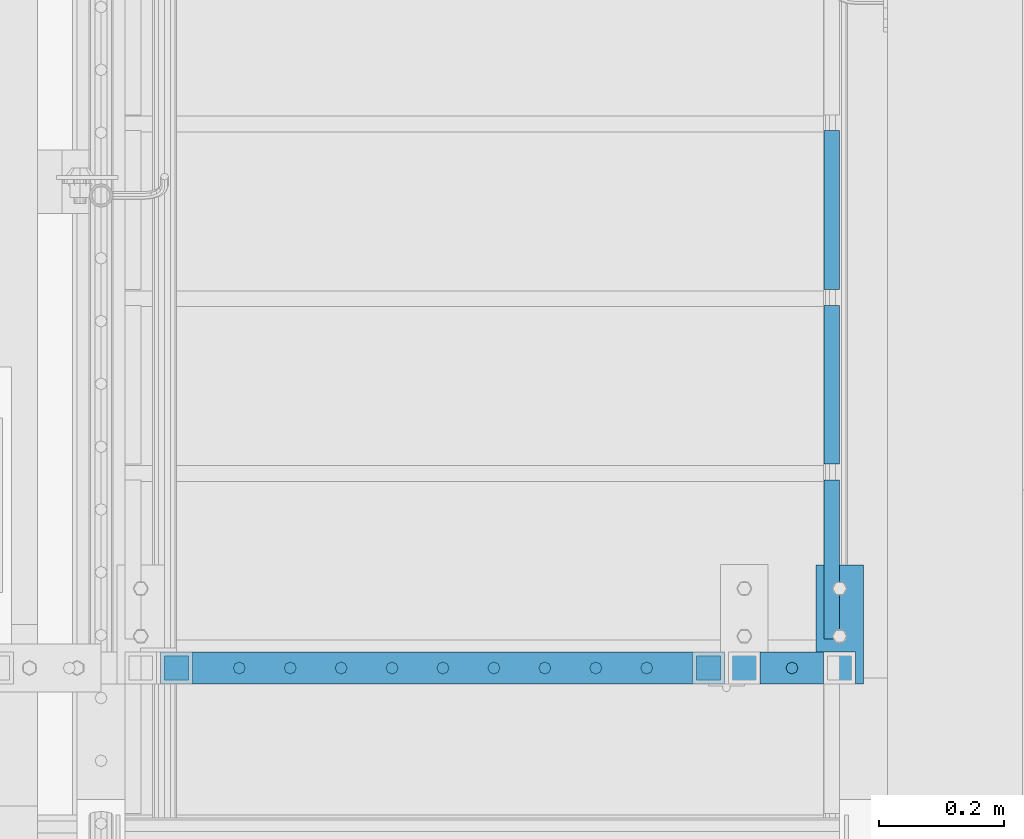
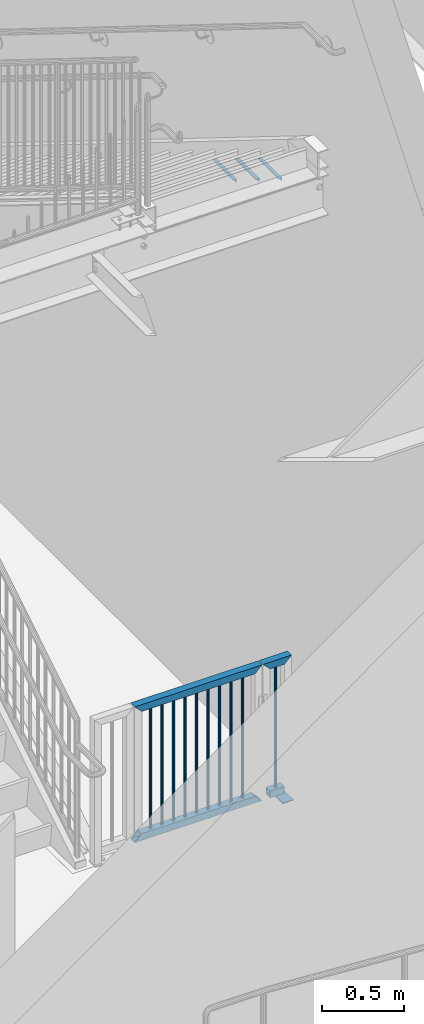
# One storey, part 1264 of 1763: 18 beams, 2 elements without a shape of their own.
"""IFC2X3 building model written with IfcOpenShell, lengths in millimetres."""

from ifc_helpers import new_model, si_unit, frame, origin_with_axes, place, context, subcontext, project, spatial, faceted_brep, material, type_object, element, aggregate, save


model = new_model("IFC2X3")

# Units and contexts
model_context = context("Model", 3, precision=1e-05, world=origin_with_axes())
body_context = subcontext(model_context, "Body", "Model", "MODEL_VIEW")
ifc_project = project(units=[si_unit("LENGTHUNIT", "METRE", prefix="MILLI"), si_unit("AREAUNIT", "SQUARE_METRE"), si_unit("VOLUMEUNIT", "CUBIC_METRE"), si_unit("MASSUNIT", "GRAM", prefix="KILO"), si_unit("TIMEUNIT", "SECOND"), si_unit("PLANEANGLEUNIT", "RADIAN"), si_unit("SOLIDANGLEUNIT", "STERADIAN"), si_unit("THERMODYNAMICTEMPERATUREUNIT", "DEGREE_CELSIUS"), si_unit("LUMINOUSINTENSITYUNIT", "LUMEN")], contexts=[model_context])

# Site, building, storey
site_placement = place(None, origin_with_axes())
site = spatial("IfcSite", under=ifc_project, at=site_placement, CompositionType="ELEMENT")
building_placement = place(site_placement, origin_with_axes())
building = spatial("IfcBuilding", under=site, at=building_placement, Name="Undefined", CompositionType="ELEMENT")
storey_placement = place(building_placement, origin_with_axes())
storey = spatial("IfcBuildingStorey", under=building, at=storey_placement, Name="Undefined", CompositionType="ELEMENT", Elevation=0.0)

# Assembly, beams
assembly_1_placement = place(storey_placement, origin_with_axes())
assembly_1 = element("IfcElementAssembly", 1, at=assembly_1_placement, inside=storey, Name="GATE", AssemblyPlace="NOTDEFINED", PredefinedType="RIGID_FRAME")
ifc_material_1 = material(Name="STEEL/A36")
beam_type_1 = type_object("IfcBeamType", PredefinedType="NOTDEFINED")
beam_1_placement = place(assembly_1_placement, frame((-84136.9372737343, 32092.9000064728, 307.975030132566), z_axis=(0.0, 1.0, 0.0), x_axis=(1.0, 0.0, 0.0)))
beam_1 = element("IfcBeam", 2, at=beam_1_placement, type_object=beam_type_1, material=ifc_material_1, context=body_context, shape_type="Brep", body=[
    faceted_brep([(0.0, 3.17500000000001, -95.25), (0.0, 3.17499999999927, 95.25), (76.1999968561649, 3.17499999984284, 95.25), (76.1999999999971, 3.17500000000001, -95.25), (0.0, -3.17499999999927, 95.25), (76.1999970403122, -3.17500000015571, 95.25), (0.0, -3.17500000000001, -95.25), (76.1999999999971, -3.17500000000001, -95.25)], [[[0, 1, 2, 3]], [[1, 4, 5, 2]], [[4, 6, 7, 5]], [[6, 0, 3, 7]], [[5, 7, 3, 2]], [[6, 4, 1, 0]]]),
])
beam_type_2 = type_object("IfcBeamType", PredefinedType="NOTDEFINED")
beam_2_placement = place(assembly_1_placement, frame((-84407.3725678519, 32023.0500064728, 1346.20003013257), z_axis=(1.0, 0.0, 0.0), x_axis=(0.0, 0.0, -1.0)))
beam_2 = element("IfcBeam", 3, at=beam_2_placement, type_object=beam_type_2, material=ifc_material_1, Name="PICKET", context=body_context, shape_type="Brep", body=[
    faceted_brep([(0.0, -9.52500000000146, 0.0), (0.0, -6.73519209080041, -6.73519209079677), (913.809358181841, -6.73519209080041, -6.73519209079677), (913.809358181841, -9.52500000000146, 0.0), (0.0, 0.0, -9.52499999999418), (913.809358181841, 0.0, -9.52499999999418), (0.0, 6.73519209080041, -6.73519209079677), (913.809358181841, 6.73519209080041, -6.73519209079677), (0.0, 9.52500000000146, 0.0), (913.809358181841, 9.52500000000146, 0.0), (0.0, 6.73519209080041, 6.73519209079677), (913.809358181841, 6.73519209080041, 6.73519209079677), (0.0, 0.0, 9.52499999999418), (913.809358181841, 0.0, 9.52499999999418), (0.0, -6.73519209080041, 6.73519209079677), (913.809358181841, -6.73519209080041, 6.73519209079677)], [[[0, 1, 2, 3]], [[1, 4, 5, 2]], [[4, 6, 7, 5]], [[6, 8, 9, 7]], [[8, 10, 11, 9]], [[10, 12, 13, 11]], [[12, 14, 15, 13]], [[14, 0, 3, 15]], [[5, 7, 9, 11, 13, 15, 3, 2]], [[14, 12, 10, 8, 6, 4, 1, 0]]]),
])
beam_3_placement = place(assembly_1_placement, frame((-84488.8019796166, 32023.0500064728, 1346.20003013257), z_axis=(1.0, 0.0, 0.0), x_axis=(0.0, 0.0, -1.0)))
beam_3 = element("IfcBeam", 4, at=beam_3_placement, type_object=beam_type_2, material=ifc_material_1, Name="PICKET", context=body_context, shape_type="Brep", body=[
    faceted_brep([(0.0, -9.52500000000146, 0.0), (0.0, -6.73519209080041, -6.73519209079677), (913.809358181841, -6.73519209080041, -6.73519209079677), (913.809358181841, -9.52500000000146, 0.0), (0.0, 0.0, -9.52499999999418), (913.809358181841, 0.0, -9.52499999999418), (0.0, 6.73519209080041, -6.73519209079677), (913.809358181841, 6.73519209080041, -6.73519209079677), (0.0, 9.52500000000146, 0.0), (913.809358181841, 9.52500000000146, 0.0), (0.0, 6.73519209080041, 6.73519209079677), (913.809358181841, 6.73519209080041, 6.73519209079677), (0.0, 0.0, 9.52499999999418), (913.809358181841, 0.0, 9.52499999999418), (0.0, -6.73519209080041, 6.73519209079677), (913.809358181841, -6.73519209080041, 6.73519209079677)], [[[0, 1, 2, 3]], [[1, 4, 5, 2]], [[4, 6, 7, 5]], [[6, 8, 9, 7]], [[8, 10, 11, 9]], [[10, 12, 13, 11]], [[12, 14, 15, 13]], [[14, 0, 3, 15]], [[5, 7, 9, 11, 13, 15, 3, 2]], [[14, 12, 10, 8, 6, 4, 1, 0]]]),
])
beam_4_placement = place(assembly_1_placement, frame((-84570.2313913813, 32023.0500064728, 1346.20003013257), z_axis=(1.0, 0.0, 0.0), x_axis=(0.0, 0.0, -1.0)))
beam_4 = element("IfcBeam", 5, at=beam_4_placement, type_object=beam_type_2, material=ifc_material_1, Name="PICKET", context=body_context, shape_type="Brep", body=[
    faceted_brep([(0.0, -9.52500000000146, 0.0), (0.0, -6.73519209080041, -6.73519209079677), (913.809358181841, -6.73519209080041, -6.73519209079677), (913.809358181841, -9.52500000000146, 0.0), (0.0, 0.0, -9.52499999999418), (913.809358181841, 0.0, -9.52499999999418), (0.0, 6.73519209080041, -6.73519209079677), (913.809358181841, 6.73519209080041, -6.73519209079677), (0.0, 9.52500000000146, 0.0), (913.809358181841, 9.52500000000146, 0.0), (0.0, 6.73519209080041, 6.73519209079677), (913.809358181841, 6.73519209080041, 6.73519209079677), (0.0, 0.0, 9.52499999999418), (913.809358181841, 0.0, 9.52499999999418), (0.0, -6.73519209080041, 6.73519209079677), (913.809358181841, -6.73519209080041, 6.73519209079677)], [[[0, 1, 2, 3]], [[1, 4, 5, 2]], [[4, 6, 7, 5]], [[6, 8, 9, 7]], [[8, 10, 11, 9]], [[10, 12, 13, 11]], [[12, 14, 15, 13]], [[14, 0, 3, 15]], [[5, 7, 9, 11, 13, 15, 3, 2]], [[14, 12, 10, 8, 6, 4, 1, 0]]]),
])
beam_5_placement = place(assembly_1_placement, frame((-84651.660803146, 32023.0500064728, 1346.20003013257), z_axis=(1.0, 0.0, 0.0), x_axis=(0.0, 0.0, -1.0)))
beam_5 = element("IfcBeam", 6, at=beam_5_placement, type_object=beam_type_2, material=ifc_material_1, Name="PICKET", context=body_context, shape_type="Brep", body=[
    faceted_brep([(0.0, -9.52500000000146, 0.0), (0.0, -6.73519209080041, -6.73519209079677), (913.809358181841, -6.73519209080041, -6.73519209079677), (913.809358181841, -9.52500000000146, 0.0), (0.0, 0.0, -9.52499999999418), (913.809358181841, 0.0, -9.52499999999418), (0.0, 6.73519209080041, -6.73519209079677), (913.809358181841, 6.73519209080041, -6.73519209079677), (0.0, 9.52500000000146, 0.0), (913.809358181841, 9.52500000000146, 0.0), (0.0, 6.73519209080041, 6.73519209079677), (913.809358181841, 6.73519209080041, 6.73519209079677), (0.0, 0.0, 9.52499999999418), (913.809358181841, 0.0, 9.52499999999418), (0.0, -6.73519209080041, 6.73519209079677), (913.809358181841, -6.73519209080041, 6.73519209079677)], [[[0, 1, 2, 3]], [[1, 4, 5, 2]], [[4, 6, 7, 5]], [[6, 8, 9, 7]], [[8, 10, 11, 9]], [[10, 12, 13, 11]], [[12, 14, 15, 13]], [[14, 0, 3, 15]], [[5, 7, 9, 11, 13, 15, 3, 2]], [[14, 12, 10, 8, 6, 4, 1, 0]]]),
])
beam_6_placement = place(assembly_1_placement, frame((-84733.0902149108, 32023.0500064728, 1346.20003013257), z_axis=(1.0, 0.0, 0.0), x_axis=(0.0, 0.0, -1.0)))
beam_6 = element("IfcBeam", 7, at=beam_6_placement, type_object=beam_type_2, material=ifc_material_1, Name="PICKET", context=body_context, shape_type="Brep", body=[
    faceted_brep([(0.0, -9.52500000000146, 0.0), (0.0, -6.73519209080041, -6.73519209079677), (913.809358181841, -6.73519209080041, -6.73519209079677), (913.809358181841, -9.52500000000146, 0.0), (0.0, 0.0, -9.52499999999418), (913.809358181841, 0.0, -9.52499999999418), (0.0, 6.73519209080041, -6.73519209079677), (913.809358181841, 6.73519209080041, -6.73519209079677), (0.0, 9.52500000000146, 0.0), (913.809358181841, 9.52500000000146, 0.0), (0.0, 6.73519209080041, 6.73519209079677), (913.809358181841, 6.73519209080041, 6.73519209079677), (0.0, 0.0, 9.52499999999418), (913.809358181841, 0.0, 9.52499999999418), (0.0, -6.73519209080041, 6.73519209079677), (913.809358181841, -6.73519209080041, 6.73519209079677)], [[[0, 1, 2, 3]], [[1, 4, 5, 2]], [[4, 6, 7, 5]], [[6, 8, 9, 7]], [[8, 10, 11, 9]], [[10, 12, 13, 11]], [[12, 14, 15, 13]], [[14, 0, 3, 15]], [[5, 7, 9, 11, 13, 15, 3, 2]], [[14, 12, 10, 8, 6, 4, 1, 0]]]),
])
beam_7_placement = place(assembly_1_placement, frame((-84814.5196266755, 32023.0500064728, 1346.20003013257), z_axis=(1.0, 0.0, 0.0), x_axis=(0.0, 0.0, -1.0)))
beam_7 = element("IfcBeam", 8, at=beam_7_placement, type_object=beam_type_2, material=ifc_material_1, Name="PICKET", context=body_context, shape_type="Brep", body=[
    faceted_brep([(0.0, -9.52500000000146, 0.0), (0.0, -6.73519209080041, -6.73519209079677), (913.809358181841, -6.73519209080041, -6.73519209079677), (913.809358181841, -9.52500000000146, 0.0), (0.0, 0.0, -9.52499999999418), (913.809358181841, 0.0, -9.52499999999418), (0.0, 6.73519209080041, -6.73519209079677), (913.809358181841, 6.73519209080041, -6.73519209079677), (0.0, 9.52500000000146, 0.0), (913.809358181841, 9.52500000000146, 0.0), (0.0, 6.73519209080041, 6.73519209079677), (913.809358181841, 6.73519209080041, 6.73519209079677), (0.0, 0.0, 9.52499999999418), (913.809358181841, 0.0, 9.52499999999418), (0.0, -6.73519209080041, 6.73519209079677), (913.809358181841, -6.73519209080041, 6.73519209079677)], [[[0, 1, 2, 3]], [[1, 4, 5, 2]], [[4, 6, 7, 5]], [[6, 8, 9, 7]], [[8, 10, 11, 9]], [[10, 12, 13, 11]], [[12, 14, 15, 13]], [[14, 0, 3, 15]], [[5, 7, 9, 11, 13, 15, 3, 2]], [[14, 12, 10, 8, 6, 4, 1, 0]]]),
])
beam_8_placement = place(assembly_1_placement, frame((-84895.9490384402, 32023.0500064728, 1346.20003013257), z_axis=(1.0, 0.0, 0.0), x_axis=(0.0, 0.0, -1.0)))
beam_8 = element("IfcBeam", 9, at=beam_8_placement, type_object=beam_type_2, material=ifc_material_1, Name="PICKET", context=body_context, shape_type="Brep", body=[
    faceted_brep([(0.0, -9.52500000000146, 0.0), (0.0, -6.73519209080041, -6.73519209079677), (913.809358181841, -6.73519209080041, -6.73519209079677), (913.809358181841, -9.52500000000146, 0.0), (0.0, 0.0, -9.52499999999418), (913.809358181841, 0.0, -9.52499999999418), (0.0, 6.73519209080041, -6.73519209079677), (913.809358181841, 6.73519209080041, -6.73519209079677), (0.0, 9.52500000000146, 0.0), (913.809358181841, 9.52500000000146, 0.0), (0.0, 6.73519209080041, 6.73519209079677), (913.809358181841, 6.73519209080041, 6.73519209079677), (0.0, 0.0, 9.52499999999418), (913.809358181841, 0.0, 9.52499999999418), (0.0, -6.73519209080041, 6.73519209079677), (913.809358181841, -6.73519209080041, 6.73519209079677)], [[[0, 1, 2, 3]], [[1, 4, 5, 2]], [[4, 6, 7, 5]], [[6, 8, 9, 7]], [[8, 10, 11, 9]], [[10, 12, 13, 11]], [[12, 14, 15, 13]], [[14, 0, 3, 15]], [[5, 7, 9, 11, 13, 15, 3, 2]], [[14, 12, 10, 8, 6, 4, 1, 0]]]),
])
beam_9_placement = place(assembly_1_placement, frame((-84977.3784502049, 32023.0500064728, 1346.20003013257), z_axis=(1.0, 0.0, 0.0), x_axis=(0.0, 0.0, -1.0)))
beam_9 = element("IfcBeam", 10, at=beam_9_placement, type_object=beam_type_2, material=ifc_material_1, Name="PICKET", context=body_context, shape_type="Brep", body=[
    faceted_brep([(0.0, -9.52500000000146, 0.0), (0.0, -6.73519209080041, -6.73519209079677), (913.809358181841, -6.73519209080041, -6.73519209079677), (913.809358181841, -9.52500000000146, 0.0), (0.0, 0.0, -9.52499999999418), (913.809358181841, 0.0, -9.52499999999418), (0.0, 6.73519209080041, -6.73519209079677), (913.809358181841, 6.73519209080041, -6.73519209079677), (0.0, 9.52500000000146, 0.0), (913.809358181841, 9.52500000000146, 0.0), (0.0, 6.73519209080041, 6.73519209079677), (913.809358181841, 6.73519209080041, 6.73519209079677), (0.0, 0.0, 9.52499999999418), (913.809358181841, 0.0, 9.52499999999418), (0.0, -6.73519209080041, 6.73519209079677), (913.809358181841, -6.73519209080041, 6.73519209079677)], [[[0, 1, 2, 3]], [[1, 4, 5, 2]], [[4, 6, 7, 5]], [[6, 8, 9, 7]], [[8, 10, 11, 9]], [[10, 12, 13, 11]], [[12, 14, 15, 13]], [[14, 0, 3, 15]], [[5, 7, 9, 11, 13, 15, 3, 2]], [[14, 12, 10, 8, 6, 4, 1, 0]]]),
])
beam_10_placement = place(assembly_1_placement, frame((-85058.8078619696, 32023.0500064728, 1346.20003013257), z_axis=(1.0, 0.0, 0.0), x_axis=(0.0, 0.0, -1.0)))
beam_10 = element("IfcBeam", 11, at=beam_10_placement, type_object=beam_type_2, material=ifc_material_1, Name="PICKET", context=body_context, shape_type="Brep", body=[
    faceted_brep([(0.0, -9.52500000000146, 0.0), (0.0, -6.73519209080041, -6.73519209079677), (913.809358181841, -6.73519209080041, -6.73519209079677), (913.809358181841, -9.52500000000146, 0.0), (0.0, 0.0, -9.52499999999418), (913.809358181841, 0.0, -9.52499999999418), (0.0, 6.73519209080041, -6.73519209079677), (913.809358181841, 6.73519209080041, -6.73519209079677), (0.0, 9.52500000000146, 0.0), (913.809358181841, 9.52500000000146, 0.0), (0.0, 6.73519209080041, 6.73519209079677), (913.809358181841, 6.73519209080041, 6.73519209079677), (0.0, 0.0, 9.52499999999418), (913.809358181841, 0.0, 9.52499999999418), (0.0, -6.73519209080041, 6.73519209079677), (913.809358181841, -6.73519209080041, 6.73519209079677)], [[[0, 1, 2, 3]], [[1, 4, 5, 2]], [[4, 6, 7, 5]], [[6, 8, 9, 7]], [[8, 10, 11, 9]], [[10, 12, 13, 11]], [[12, 14, 15, 13]], [[14, 0, 3, 15]], [[5, 7, 9, 11, 13, 15, 3, 2]], [[14, 12, 10, 8, 6, 4, 1, 0]]]),
])
beam_11_placement = place(assembly_1_placement, frame((-84175.0372737343, 32023.0500064728, 1346.20003013257), z_axis=(1.0, 0.0, 0.0), x_axis=(0.0, 0.0, -1.0)))
beam_11 = element("IfcBeam", 12, at=beam_11_placement, type_object=beam_type_2, material=ifc_material_1, Name="PICKET", context=body_context, shape_type="Brep", body=[
    faceted_brep([(0.0, -9.52500000000146, 0.0), (0.0, -6.73519209080041, -6.73519209079677), (914.401840643747, -6.73519209080041, -6.73519209079677), (914.401840643747, -9.52500000000146, 0.0), (0.0, 0.0, -9.52499999999418), (914.401840643747, 0.0, -9.52499999999418), (0.0, 6.73519209080041, -6.73519209079677), (914.401840643747, 6.73519209080041, -6.73519209079677), (0.0, 9.52500000000146, 0.0), (914.401840643747, 9.52500000000146, 0.0), (0.0, 6.73519209080041, 6.73519209079677), (914.401840643747, 6.73519209080041, 6.73519209079677), (0.0, 0.0, 9.52499999999418), (914.401840643747, 0.0, 9.52499999999418), (0.0, -6.73519209080041, 6.73519209079677), (914.401840643747, -6.73519209080041, 6.73519209079677)], [[[0, 1, 2, 3]], [[1, 4, 5, 2]], [[4, 6, 7, 5]], [[6, 8, 9, 7]], [[8, 10, 11, 9]], [[10, 12, 13, 11]], [[12, 14, 15, 13]], [[14, 0, 3, 15]], [[5, 7, 9, 11, 13, 15, 3, 2]], [[14, 12, 10, 8, 6, 4, 1, 0]]]),
])
ifc_material_2 = material()
beam_type_3 = type_object("IfcBeamType", Name="HSS2X2X1/4", PredefinedType="NOTDEFINED")
beam_12_placement = place(assembly_1_placement, frame((-84251.2372737343, 32023.0500064728, 406.39818948882), z_axis=(0.0, 0.0, 1.0), x_axis=(1.0, 0.0, 0.0)))
beam_12 = element("IfcBeam", 13, at=beam_12_placement, type_object=beam_type_3, material=ifc_material_2, Name="GUARDRAIL", ObjectType="HSS2X2X1/4", context=body_context, shape_type="Brep", body=[
    faceted_brep([(25.3999999999942, 19.0499999999993, -19.05), (25.3999999999942, -19.0499999999993, -19.05), (127.000000000015, -19.0499999999993, -19.05), (127.000000000015, 19.0499999999993, -19.05), (25.3999999999942, -19.0499999999993, 19.05), (127.000000000015, -19.0499999999993, 19.05), (25.3999999999942, 19.0499999999993, 19.05), (127.000000000015, 19.0499999999993, 19.05), (25.400000000006, 25.4000000000015, -25.3999999999942), (25.4000000000001, 25.4000000000015, 25.3999999999942), (127.000000000015, 25.4000000000015, 25.4), (127.000000000015, 25.4000000000015, -25.4), (25.4000000000001, -25.4000000000015, 25.3999999999942), (127.000000000015, -25.4000000000015, 25.4), (25.400000000006, -25.4000000000015, -25.3999999999942), (127.000000000015, -25.4000000000015, -25.4)], [[[0, 1, 2, 3]], [[1, 4, 5, 2]], [[4, 6, 7, 5]], [[6, 0, 3, 7]], [[8, 9, 10, 11]], [[9, 12, 13, 10]], [[12, 14, 15, 13]], [[14, 8, 11, 15]], [[13, 15, 11, 10], [5, 7, 3, 2]], [[14, 12, 9, 8], [6, 4, 1, 0]]]),
])
beam_13_placement = place(assembly_1_placement, frame((-85159.2872737343, 32023.0500064728, 406.39818948882), z_axis=(0.0, 0.0, 1.0), x_axis=(1.0, 0.0, 0.0)))
beam_13 = element("IfcBeam", 14, at=beam_13_placement, type_object=beam_type_3, material=ifc_material_2, Name="GUARDRAIL", ObjectType="HSS2X2X1/4", context=body_context, shape_type="Brep", body=[
    faceted_brep([(-19.0500000000052, 19.0499999999993, -19.0500000000029), (-19.0500000000052, -19.0499999999993, -19.0500000000029), (869.949999999997, -19.0499999999993, -19.05), (869.949999999997, 19.0499999999993, -19.05), (19.0499999999993, -19.0499999999993, 19.0500000000029), (831.850000000006, -19.0499999999993, 19.05), (19.0499999999993, 19.0499999999993, 19.0500000000029), (831.850000000006, 19.0499999999993, 19.05), (-25.400000000006, 25.4000000000015, -25.3999999999942), (25.4000000000001, 25.4000000000015, 25.3999999999942), (825.500000000015, 25.4000000000015, 25.4), (876.300000000003, 25.4000000000015, -25.4), (25.4000000000001, -25.4000000000015, 25.3999999999942), (825.500000000015, -25.4000000000015, 25.4), (-25.400000000006, -25.4000000000015, -25.3999999999942), (876.300000000003, -25.4000000000015, -25.4)], [[[0, 1, 2, 3]], [[1, 4, 5, 2]], [[4, 6, 7, 5]], [[6, 0, 3, 7]], [[8, 9, 10, 11]], [[9, 12, 13, 10]], [[12, 14, 15, 13]], [[14, 8, 11, 15]], [[13, 15, 11, 10], [5, 7, 3, 2]], [[14, 12, 9, 8], [6, 4, 1, 0]]]),
])
beam_14_placement = place(assembly_1_placement, frame((-84251.2372737343, 32023.0500064728, 1371.60003013257), z_axis=(0.0, 0.0, 1.0), x_axis=(1.0, 0.0, 0.0)))
beam_14 = element("IfcBeam", 15, at=beam_14_placement, type_object=beam_type_3, material=ifc_material_2, Name="GUARDRAIL", ObjectType="HSS2X2X1/4", context=body_context, shape_type="Brep", body=[
    faceted_brep([(19.0500000000052, 19.0499999999993, -19.0500000000029), (19.0500000000052, -19.0499999999993, -19.0500000000029), (133.350000000006, -19.0499999999993, -19.05), (133.350000000006, 19.0499999999993, -19.05), (-19.0499999999993, -19.0499999999993, 19.0500000000029), (171.449999999997, -19.0499999999993, 19.05), (-19.0499999999993, 19.0499999999993, 19.0500000000029), (171.449999999997, 19.0499999999993, 19.05), (25.400000000006, 25.4000000000015, -25.3999999999942), (-25.4000000000001, 25.4000000000015, 25.3999999999942), (177.799999999988, 25.4000000000015, 25.4000000000001), (127.000000000015, 25.4000000000015, -25.4), (-25.4000000000001, -25.4000000000015, 25.3999999999942), (177.799999999988, -25.4000000000015, 25.4000000000001), (25.400000000006, -25.4000000000015, -25.3999999999942), (127.000000000015, -25.4000000000015, -25.4)], [[[0, 1, 2, 3]], [[1, 4, 5, 2]], [[4, 6, 7, 5]], [[6, 0, 3, 7]], [[8, 9, 10, 11]], [[9, 12, 13, 10]], [[12, 14, 15, 13]], [[14, 8, 11, 15]], [[13, 15, 11, 10], [5, 7, 3, 2]], [[14, 12, 9, 8], [6, 4, 1, 0]]]),
])
beam_15_placement = place(assembly_1_placement, frame((-85159.2872737343, 32023.0500064728, 1371.60003013257), z_axis=(0.0, 0.0, 1.0), x_axis=(1.0, 0.0, 0.0)))
beam_15 = element("IfcBeam", 16, at=beam_15_placement, type_object=beam_type_3, material=ifc_material_2, Name="GATE", ObjectType="HSS2X2X1/4", context=body_context, shape_type="Brep", body=[
    faceted_brep([(19.0500000000052, 19.0499999999993, -19.0500000000029), (19.0500000000052, -19.0499999999993, -19.0500000000029), (831.85000000002, -19.0499999999993, -19.05), (831.85000000002, 19.0499999999993, -19.05), (-19.0499999999993, -19.0499999999993, 19.0500000000029), (869.950000000012, -19.0499999999993, 19.05), (-19.0499999999993, 19.0499999999993, 19.0500000000029), (869.950000000012, 19.0499999999993, 19.05), (25.400000000006, 25.4000000000015, -25.3999999999942), (-25.4000000000001, 25.4000000000015, 25.3999999999942), (876.300000000003, 25.4000000000015, 25.4000000000001), (825.500000000015, 25.4000000000015, -25.4000000000001), (-25.4000000000001, -25.4000000000015, 25.3999999999942), (876.300000000003, -25.4000000000015, 25.4000000000001), (25.400000000006, -25.4000000000015, -25.3999999999942), (825.500000000015, -25.4000000000015, -25.4000000000001)], [[[0, 1, 2, 3]], [[1, 4, 5, 2]], [[4, 6, 7, 5]], [[6, 0, 3, 7]], [[8, 9, 10, 11]], [[9, 12, 13, 10]], [[12, 14, 15, 13]], [[14, 8, 11, 15]], [[13, 15, 11, 10], [5, 7, 3, 2]], [[14, 12, 9, 8], [6, 4, 1, 0]]]),
])
aggregate(assembly_1, [beam_1, beam_2, beam_3, beam_4, beam_5, beam_6, beam_7, beam_8, beam_9, beam_10, beam_11, beam_12, beam_13, beam_14, beam_15])

assembly_2_placement = place(storey_placement, origin_with_axes())
assembly_2 = element("IfcElementAssembly", 17, at=assembly_2_placement, inside=storey, Name="STRINGER", AssemblyPlace="NOTDEFINED", PredefinedType="RIGID_FRAME")
beam_type_4 = type_object("IfcBeamType", Name="L1X1X1/8", PredefinedType="NOTDEFINED")
beam_16_placement = place(assembly_2_placement, frame((-84111.472101103, 32323.5524594165, 4920.40333353658), z_axis=(-1.0, 0.0, 0.0), x_axis=(0.0, -1.0, 0.0)))
beam_16 = element("IfcBeam", 18, at=beam_16_placement, type_object=beam_type_4, material=ifc_material_1, Name="ANGLE", ObjectType="L1X1X1/8", context=body_context, shape_type="Brep", body=[
    faceted_brep([(3.93434019839663e-12, 12.6999999999978, -12.6999998092651), (-1.31614667686587e-12, 12.6999999999978, 12.6999998092651), (254.0, 12.69999981, 12.6999998099927), (254.0, 12.69999981, -12.6999998099927), (-1.06936913171421e-12, 9.52499999999854, 12.699999332428), (254.0, 9.52499985799977, 12.6999998099927), (0.0, 9.52499985799977, -9.52499985799659), (254.0, 9.52499985799977, -9.52499985799659), (0.0, -12.69999981, -9.52499985799659), (254.0, -12.69999981, -9.52499985799659), (0.0, -12.69999981, -12.6999998099927), (254.0, -12.69999981, -12.6999998099927)], [[[0, 1, 2, 3]], [[1, 4, 5, 2]], [[4, 6, 7, 5]], [[6, 8, 9, 7]], [[8, 10, 11, 9]], [[10, 0, 3, 11]], [[5, 7, 9, 11, 3, 2]], [[10, 8, 6, 4, 1, 0]]]),
])
beam_17_placement = place(assembly_2_placement, frame((-84111.472101103, 32602.9524595004, 4746.94250020325), z_axis=(-1.0, 0.0, 0.0), x_axis=(0.0, -1.0, 0.0)))
beam_17 = element("IfcBeam", 19, at=beam_17_placement, type_object=beam_type_4, material=ifc_material_1, Name="ANGLE", ObjectType="L1X1X1/8", context=body_context, shape_type="Brep", body=[
    faceted_brep([(3.93434019839663e-12, 12.6999999999978, -12.6999998092651), (-1.31614667686587e-12, 12.6999999999978, 12.6999998092651), (254.0, 12.69999981, 12.6999998099927), (254.0, 12.69999981, -12.6999998099927), (-1.06936913171421e-12, 9.52499999999854, 12.699999332428), (254.0, 9.52499985799977, 12.6999998099927), (0.0, 9.52499985799977, -9.52499985799659), (254.0, 9.52499985799977, -9.52499985799659), (0.0, -12.69999981, -9.52499985799659), (254.0, -12.69999981, -9.52499985799659), (0.0, -12.69999981, -12.6999998099927), (254.0, -12.69999981, -12.6999998099927)], [[[0, 1, 2, 3]], [[1, 4, 5, 2]], [[4, 6, 7, 5]], [[6, 8, 9, 7]], [[8, 10, 11, 9]], [[10, 0, 3, 11]], [[5, 7, 9, 11, 3, 2]], [[10, 8, 6, 4, 1, 0]]]),
])
beam_18_placement = place(assembly_2_placement, frame((-84111.472101103, 32882.3524595843, 4573.48166686991), z_axis=(-1.0, 0.0, 0.0), x_axis=(0.0, -1.0, 0.0)))
beam_18 = element("IfcBeam", 20, at=beam_18_placement, type_object=beam_type_4, material=ifc_material_1, Name="ANGLE", ObjectType="L1X1X1/8", context=body_context, shape_type="Brep", body=[
    faceted_brep([(3.93434019839663e-12, 12.6999999999978, -12.6999998092651), (-1.31614667686587e-12, 12.6999999999978, 12.6999998092651), (254.0, 12.69999981, 12.6999998099927), (254.0, 12.69999981, -12.6999998099927), (-1.06936913171421e-12, 9.52499999999854, 12.699999332428), (254.0, 9.52499985799977, 12.6999998099927), (0.0, 9.52499985799977, -9.52499985799659), (254.0, 9.52499985799977, -9.52499985799659), (0.0, -12.69999981, -9.52499985799659), (254.0, -12.69999981, -9.52499985799659), (0.0, -12.69999981, -12.6999998099927), (254.0, -12.69999981, -12.6999998099927)], [[[0, 1, 2, 3]], [[1, 4, 5, 2]], [[4, 6, 7, 5]], [[6, 8, 9, 7]], [[8, 10, 11, 9]], [[10, 0, 3, 11]], [[5, 7, 9, 11, 3, 2]], [[10, 8, 6, 4, 1, 0]]]),
])
aggregate(assembly_2, [beam_16, beam_17, beam_18])

save(model, "model.ifc")
